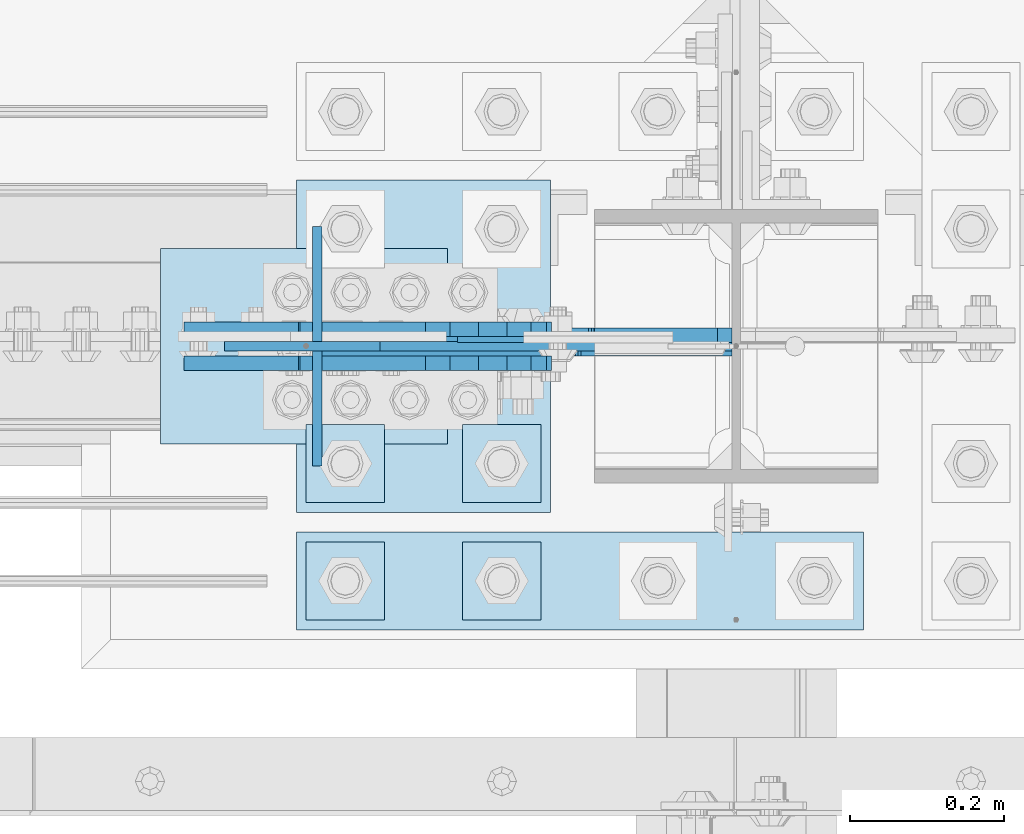
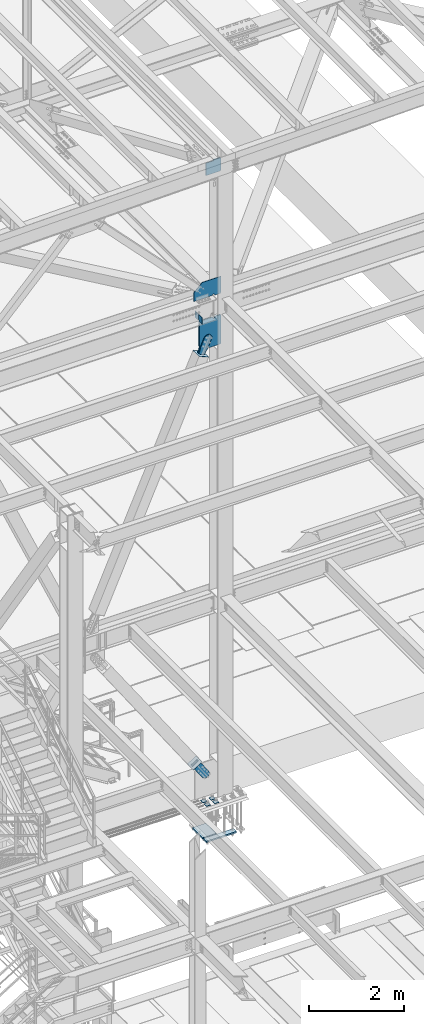
# One storey, part 3181 of 3843: 17 plates, 9 elements without a shape of their own.
"""IFC2X3 building model written with IfcOpenShell, lengths in millimetres."""

from ifc_helpers import new_model, si_unit, frame, origin_with_axes, place, context, subcontext, project, spatial, faceted_brep, material, type_object, element, aggregate, save


model = new_model("IFC2X3")

# Units and contexts
model_context = context("Model", 3, precision=1e-05, world=origin_with_axes())
body_context = subcontext(model_context, "Body", "Model", "MODEL_VIEW")
ifc_project = project(units=[si_unit("LENGTHUNIT", "METRE", prefix="MILLI"), si_unit("AREAUNIT", "SQUARE_METRE"), si_unit("VOLUMEUNIT", "CUBIC_METRE"), si_unit("MASSUNIT", "GRAM", prefix="KILO"), si_unit("TIMEUNIT", "SECOND"), si_unit("PLANEANGLEUNIT", "RADIAN"), si_unit("SOLIDANGLEUNIT", "STERADIAN"), si_unit("THERMODYNAMICTEMPERATUREUNIT", "DEGREE_CELSIUS"), si_unit("LUMINOUSINTENSITYUNIT", "LUMEN")], contexts=[model_context])

# Site, building, storey
site_placement = place(None, origin_with_axes())
site = spatial("IfcSite", under=ifc_project, at=site_placement, CompositionType="ELEMENT")
building_placement = place(site_placement, origin_with_axes())
building = spatial("IfcBuilding", under=site, at=building_placement, Name="Undefined", CompositionType="ELEMENT")
storey_placement = place(building_placement, origin_with_axes())
storey = spatial("IfcBuildingStorey", under=building, at=storey_placement, Name="Undefined", CompositionType="ELEMENT", Elevation=0.0)

# Assembly, plates
assembly_1_placement = place(storey_placement, origin_with_axes())
assembly_1 = element("IfcElementAssembly", 1, at=assembly_1_placement, inside=storey, Name="BEAM", AssemblyPlace="NOTDEFINED", PredefinedType="RIGID_FRAME")
ifc_material_1 = material(Name="STEEL/A572-50")
plate_type_1 = type_object("IfcPlateType", PredefinedType="NOTDEFINED")
plate_1_placement = place(assembly_1_placement, frame((62092.0351249223, 25609.55, 42110.025), z_axis=(0.0, 0.0, -1.0), x_axis=(0.0, -1.0, 0.0)))
plate_1 = element("IfcPlate", 2, at=plate_1_placement, type_object=plate_type_1, material=ifc_material_1, Name="PLATE", context=body_context, shape_type="Brep", body=[
    faceted_brep([(0.0, -6.3499999046162, 0.0), (0.0, -6.35000000000582, 131.762499999997), (0.0, 6.35000000000582, 131.762499999997), (7.27595761418343e-12, 6.3499999046162, 0.0), (31.75, -6.35000000000582, 163.512499999997), (31.75, 6.35000000000582, 163.512499999997), (149.224999999991, -6.35000000000582, 163.512499999997), (149.224999999991, 6.35000000000582, 163.512499999997), (149.224999999991, -6.35000000000582, 0.0), (149.224999999991, 6.35000000000582, 0.0)], [[[0, 1, 2, 3]], [[1, 4, 5, 2]], [[4, 6, 7, 5]], [[6, 8, 9, 7]], [[8, 0, 3, 9]], [[5, 7, 9, 3, 2]], [[8, 6, 4, 1, 0]]]),
])
plate_2_placement = place(assembly_1_placement, frame((62092.0351249223, 25771.475, 42110.025), z_axis=(0.0, 0.0, -1.0), x_axis=(0.0, -1.0, 0.0)))
plate_2 = element("IfcPlate", 3, at=plate_2_placement, type_object=plate_type_1, material=ifc_material_1, Name="PLATE", context=body_context, shape_type="Brep", body=[
    faceted_brep([(0.0, -6.3499999046162, 0.0), (0.0, -6.34999999999854, 163.512499999997), (0.0, 6.34999999999854, 163.512499999997), (7.27595761418343e-12, 6.3499999046162, 0.0), (117.474999999991, -6.34999999999854, 163.512499999997), (117.474999999991, 6.34999999999854, 163.512499999997), (149.224999999991, -6.34999999999854, 131.762499999997), (149.224999999991, 6.34999999999854, 131.762499999997), (149.224999999991, -6.35000000000582, 0.0), (149.224999999991, 6.35000000000582, 0.0)], [[[0, 1, 2, 3]], [[1, 4, 5, 2]], [[4, 6, 7, 5]], [[6, 8, 9, 7]], [[8, 0, 3, 9]], [[5, 7, 9, 3, 2]], [[8, 6, 4, 1, 0]]]),
])
aggregate(assembly_1, [plate_1, plate_2])

# Assembly, plate
assembly_2_placement = place(storey_placement, origin_with_axes())
assembly_2 = element("IfcElementAssembly", 4, at=assembly_2_placement, inside=storey, Name="COLUMN", AssemblyPlace="NOTDEFINED", PredefinedType="RIGID_FRAME")
plate_type_2 = type_object("IfcPlateType", PredefinedType="NOTDEFINED")
plate_3_placement = place(assembly_2_placement, frame((62098.3851249223, 25615.9, 42468.8), z_axis=(0.0, 0.0, -1.0), x_axis=(1.0, 0.0, 0.0)))
plate_3 = element("IfcPlate", 5, at=plate_3_placement, type_object=plate_type_2, material=ifc_material_1, Name="CB", context=body_context, shape_type="Brep", body=[
    faceted_brep([(513.296967251517, 12.7000000000007, 542.925000000003), (513.296967251517, -12.7000000000007, 542.925000000003), (379.153217251514, -12.7000000000007, 542.925000000003), (379.153217251514, 12.7000000000007, 542.925000000003), (379.153217251514, -12.7000000000007, 568.325000190736), (379.153217251514, 12.7000000000007, 568.325000190736), (378.186487328923, -12.7000000000007, 573.185079708783), (378.186487328923, 12.7000000000007, 573.185079708783), (375.433473428449, -12.7000000000007, 577.305256176936), (375.433473428449, 12.7000000000007, 577.305256176936), (371.313296960296, -12.7000000000007, 580.05827007741), (371.313296960296, 12.7000000000007, 580.05827007741), (366.453217442249, -12.7000000000007, 581.025000000001), (366.453217442249, 12.7000000000007, 581.025000000001), (341.128708774966, -12.7000000000007, 581.025000000001), (341.128708774966, 12.7000000000007, 581.025000000001), (336.26862925692, -12.7000000000007, 580.05827007741), (336.26862925692, 12.7000000000007, 580.05827007741), (332.148452788766, -12.7000000000007, 577.305256176936), (332.148452788766, 12.7000000000007, 577.305256176936), (329.395438888292, -12.7000000000007, 573.185079708783), (329.395438888292, 12.7000000000007, 573.185079708783), (328.428708965701, -12.7000000000007, 568.325000190736), (328.428708965701, 12.7000000000007, 568.325000190736), (328.428708965701, -12.7000000000007, 542.925000000003), (328.428708965701, 12.7000000000007, 542.925000000003), (0.0, -12.7000000000007, 542.925000000003), (0.0, 12.7000000000007, 542.925000000003), (0.0, -12.7000000000007, 1188.66468498625), (0.0, 12.7000000000007, 1188.66468498625), (248.782756516986, -12.7000000000007, 1298.2906209775), (248.782756516986, 12.7000000000007, 1298.2906209775), (514.090717632986, -12.7000000000007, 1298.2906209775), (514.090717632986, 12.7000000000007, 1298.2906209775), (532.45862507767, -12.7000000000007, 1279.92271353282), (532.45862507767, 12.7000000000007, 1279.92271353282), (532.45862507767, 12.7000000000007, 562.086657826156), (532.45862507767, -12.7000000000007, 562.086657826156)], [[[0, 1, 2, 3]], [[4, 5, 3, 2]], [[6, 7, 5, 4]], [[8, 9, 7, 6]], [[10, 11, 9, 8]], [[12, 13, 11, 10]], [[14, 15, 13, 12]], [[16, 17, 15, 14]], [[18, 19, 17, 16]], [[20, 21, 19, 18]], [[22, 23, 21, 20]], [[24, 25, 23, 22]], [[26, 27, 25, 24]], [[28, 29, 27, 26]], [[28, 30, 31, 29]], [[30, 32, 33, 31]], [[33, 32, 34, 35]], [[0, 3, 5, 7, 9, 11, 13, 15, 17, 19, 21, 23, 25, 27, 29, 31, 33, 35, 36]], [[1, 0, 36, 37]], [[32, 30, 28, 26, 24, 22, 20, 18, 16, 14, 12, 10, 8, 6, 4, 2, 1, 37, 34]], [[36, 35, 34, 37]]]),
])

# Assembly, plates
assembly_3_placement = place(storey_placement, origin_with_axes())
assembly_3 = element("IfcElementAssembly", 6, at=assembly_3_placement, inside=storey, Name="TEMPLATE", AssemblyPlace="NOTDEFINED", PredefinedType="RIGID_FRAME")
plate_type_3 = type_object("IfcPlateType", PredefinedType="NOTDEFINED")
plate_4_placement = place(assembly_3_placement, frame((62179.2, 25361.9, 29686.25), z_axis=(-1.0, 0.0, 0.0), x_axis=(0.0, -1.0, 0.0)))
plate_4 = element("IfcPlate", 7, at=plate_4_placement, type_object=plate_type_3, material=ifc_material_1, Name="Washer Plate", context=body_context, shape_type="Brep", body=[
    faceted_brep([(0.0, -6.3499999046162, 0.0), (-1.67347025126219e-10, -6.35000000000582, 101.600000000151), (-1.67347025126219e-10, 6.35000000000582, 101.600000000151), (7.27595761418343e-12, 6.3499999046162, 0.0), (101.599998474121, -6.34999999999854, 101.599998474121), (101.599998474121, 6.34999999999854, 101.599998474121), (101.6, -6.34999999999854, 0.0), (101.6, 6.34999999999854, 0.0)], [[[0, 1, 2, 3]], [[1, 4, 5, 2]], [[4, 6, 7, 5]], [[6, 0, 3, 7]], [[5, 7, 3, 2]], [[6, 4, 1, 0]]]),
])
plate_5_placement = place(assembly_3_placement, frame((62382.4, 25361.9, 29686.25), z_axis=(-1.0, 0.0, 0.0), x_axis=(0.0, -1.0, 0.0)))
plate_5 = element("IfcPlate", 8, at=plate_5_placement, type_object=plate_type_3, material=ifc_material_1, Name="Washer Plate", context=body_context, shape_type="Brep", body=[
    faceted_brep([(0.0, -6.3499999046162, 0.0), (-1.67347025126219e-10, -6.35000000000582, 101.600000000151), (-1.67347025126219e-10, 6.35000000000582, 101.600000000151), (7.27595761418343e-12, 6.3499999046162, 0.0), (101.599998474121, -6.34999999999854, 101.599998474121), (101.599998474121, 6.34999999999854, 101.599998474121), (101.6, -6.34999999999854, 0.0), (101.6, 6.34999999999854, 0.0)], [[[0, 1, 2, 3]], [[1, 4, 5, 2]], [[4, 6, 7, 5]], [[6, 0, 3, 7]], [[5, 7, 3, 2]], [[6, 4, 1, 0]]]),
])
plate_6_placement = place(assembly_3_placement, frame((62179.2, 25514.3, 29686.25), z_axis=(-1.0, 0.0, 0.0), x_axis=(0.0, -1.0, 0.0)))
plate_6 = element("IfcPlate", 9, at=plate_6_placement, type_object=plate_type_3, material=ifc_material_1, Name="Washer Plate", context=body_context, shape_type="Brep", body=[
    faceted_brep([(0.0, -6.3499999046162, 0.0), (-1.67347025126219e-10, -6.35000000000582, 101.600000000151), (-1.67347025126219e-10, 6.35000000000582, 101.600000000151), (7.27595761418343e-12, 6.3499999046162, 0.0), (101.599998474121, -6.34999999999854, 101.599998474121), (101.599998474121, 6.34999999999854, 101.599998474121), (101.6, -6.34999999999854, 0.0), (101.6, 6.34999999999854, 0.0)], [[[0, 1, 2, 3]], [[1, 4, 5, 2]], [[4, 6, 7, 5]], [[6, 0, 3, 7]], [[5, 7, 3, 2]], [[6, 4, 1, 0]]]),
])
plate_7_placement = place(assembly_3_placement, frame((62382.4, 25514.3, 29686.25), z_axis=(-1.0, 0.0, 0.0), x_axis=(0.0, -1.0, 0.0)))
plate_7 = element("IfcPlate", 10, at=plate_7_placement, type_object=plate_type_3, material=ifc_material_1, Name="Washer Plate", context=body_context, shape_type="Brep", body=[
    faceted_brep([(0.0, -6.3499999046162, 0.0), (-1.67347025126219e-10, -6.35000000000582, 101.600000000151), (-1.67347025126219e-10, 6.35000000000582, 101.600000000151), (7.27595761418343e-12, 6.3499999046162, 0.0), (101.599998474121, -6.34999999999854, 101.599998474121), (101.599998474121, 6.34999999999854, 101.599998474121), (101.6, -6.34999999999854, 0.0), (101.6, 6.34999999999854, 0.0)], [[[0, 1, 2, 3]], [[1, 4, 5, 2]], [[4, 6, 7, 5]], [[6, 0, 3, 7]], [[5, 7, 3, 2]], [[6, 4, 1, 0]]]),
])

# Assembly, plate
assembly_4_placement = place(storey_placement, origin_with_axes())
assembly_4 = element("IfcElementAssembly", 11, at=assembly_4_placement, inside=storey, AssemblyPlace="NOTDEFINED", PredefinedType="RIGID_FRAME")
ifc_material_2 = material(Name="STEEL/A36")
plate_type_4 = type_object("IfcPlateType", PredefinedType="NOTDEFINED")
plate_8_placement = place(assembly_4_placement, frame((62067.4857896757, 25638.125, 30671.6692954389), z_axis=(-0.825644641353306, 0.0, -0.564190505241423), x_axis=(0.564190505241422, 0.0, -0.825644641353306)))
plate_8 = element("IfcPlate", 12, at=plate_8_placement, type_object=plate_type_4, material=ifc_material_2, context=body_context, shape_type="Brep", body=[
    faceted_brep([(0.0, -9.52500000000146, 0.0), (7.37782102078199e-09, -9.52499999999418, 179.651701450231), (7.37782102078199e-09, 9.52499999999418, 179.651701450231), (0.0, 9.52500000000146, 0.0), (69.8500000062704, -9.52499999999418, 179.651701450392), (69.8500000062704, 9.52499999999418, 179.651701450392), (171.449999998309, -9.52499999999418, 186.663350727089), (171.449999998309, 9.52499999999418, 186.663350727089), (434.579297655291, -9.52499999999418, 186.663350728457), (434.579297655291, 9.52499999999418, 186.663350728457), (471.637405120986, -9.52499999999418, 179.292034842016), (471.637405120986, 9.52499999999418, 179.292034842016), (503.05375165752, -9.52499999999418, 158.300303204887), (503.05375165752, 9.52499999999418, 158.300303204887), (524.045483294532, -9.52499999999418, 126.883956668345), (524.045483294532, 9.52499999999418, 126.883956668345), (531.416799180792, -9.52499999999418, 89.8258522538526), (531.416799180792, 9.52499999999418, 89.8258522538526), (524.045483293885, -9.52499999999418, 52.7677447886235), (524.045483293885, 9.52499999999418, 52.7677447886235), (503.053751656611, -9.52499999999418, 21.3513982523873), (503.053751656611, 9.52499999999418, 21.3513982523873), (471.637405120178, -9.52499999999418, 0.359666615346214), (471.637405120178, 9.52499999999418, 0.359666615346214), (434.579299181831, -9.52499999999418, -7.01164927131322), (434.579299181831, 9.52499999999418, -7.01164927131322), (171.449999996272, -9.52499999999418, -7.01164927269565), (171.449999996272, 9.52499999999418, -7.01164927269565), (69.8499999979995, -9.52499999999418, -4.00177668780088e-10), (69.8499999979995, 9.52499999999418, -4.00177668780088e-10)], [[[0, 1, 2, 3]], [[1, 4, 5, 2]], [[4, 6, 7, 5]], [[6, 8, 9, 7]], [[8, 10, 11, 9]], [[10, 12, 13, 11]], [[12, 14, 15, 13]], [[14, 16, 17, 15]], [[16, 18, 19, 17]], [[18, 20, 21, 19]], [[20, 22, 23, 21]], [[22, 24, 25, 23]], [[24, 26, 27, 25]], [[26, 28, 29, 27]], [[28, 0, 3, 29]], [[5, 7, 9, 11, 13, 15, 17, 19, 21, 23, 25, 27, 29, 3, 2]], [[28, 26, 24, 22, 20, 18, 16, 14, 12, 10, 8, 6, 4, 1, 0]]]),
])
aggregate(assembly_4, [plate_8])

assembly_5_placement = place(storey_placement, origin_with_axes())
assembly_5 = element("IfcElementAssembly", 13, at=assembly_5_placement, inside=storey, AssemblyPlace="NOTDEFINED", PredefinedType="RIGID_FRAME")
plate_9_placement = place(assembly_5_placement, frame((62067.4857896757, 25593.675, 30671.6692954389), z_axis=(-0.825644641353306, 0.0, -0.564190505241423), x_axis=(0.564190505241422, 0.0, -0.825644641353306)))
plate_9 = element("IfcPlate", 14, at=plate_9_placement, type_object=plate_type_4, material=ifc_material_2, context=body_context, shape_type="Brep", body=[
    faceted_brep([(0.0, -9.52500000000146, 0.0), (7.37782102078199e-09, -9.52499999999418, 179.651701450231), (7.37782102078199e-09, 9.52499999999418, 179.651701450231), (0.0, 9.52500000000146, 0.0), (69.8500000062704, -9.52499999999418, 179.651701450392), (69.8500000062704, 9.52499999999418, 179.651701450392), (171.449999998309, -9.52499999999418, 186.663350727089), (171.449999998309, 9.52499999999418, 186.663350727089), (434.579297655291, -9.52499999999418, 186.663350728457), (434.579297655291, 9.52499999999418, 186.663350728457), (471.637405120986, -9.52499999999418, 179.292034842016), (471.637405120986, 9.52499999999418, 179.292034842016), (503.05375165752, -9.52499999999418, 158.300303204887), (503.05375165752, 9.52499999999418, 158.300303204887), (524.045483294532, -9.52499999999418, 126.883956668345), (524.045483294532, 9.52499999999418, 126.883956668345), (531.416799180792, -9.52499999999418, 89.8258522538526), (531.416799180792, 9.52499999999418, 89.8258522538526), (524.045483293885, -9.52499999999418, 52.7677447886235), (524.045483293885, 9.52499999999418, 52.7677447886235), (503.053751656611, -9.52499999999418, 21.3513982523873), (503.053751656611, 9.52499999999418, 21.3513982523873), (471.637405120178, -9.52499999999418, 0.359666615346214), (471.637405120178, 9.52499999999418, 0.359666615346214), (434.579299181831, -9.52499999999418, -7.01164927131322), (434.579299181831, 9.52499999999418, -7.01164927131322), (171.449999996272, -9.52499999999418, -7.01164927269565), (171.449999996272, 9.52499999999418, -7.01164927269565), (69.8499999979995, -9.52499999999418, -4.00177668780088e-10), (69.8499999979995, 9.52499999999418, -4.00177668780088e-10)], [[[0, 1, 2, 3]], [[1, 4, 5, 2]], [[4, 6, 7, 5]], [[6, 8, 9, 7]], [[8, 10, 11, 9]], [[10, 12, 13, 11]], [[12, 14, 15, 13]], [[14, 16, 17, 15]], [[16, 18, 19, 17]], [[18, 20, 21, 19]], [[20, 22, 23, 21]], [[22, 24, 25, 23]], [[24, 26, 27, 25]], [[26, 28, 29, 27]], [[28, 0, 3, 29]], [[5, 7, 9, 11, 13, 15, 17, 19, 21, 23, 25, 27, 29, 3, 2]], [[28, 26, 24, 22, 20, 18, 16, 14, 12, 10, 8, 6, 4, 1, 0]]]),
])
aggregate(assembly_5, [plate_9])

assembly_6_placement = place(storey_placement, origin_with_axes())
assembly_6 = element("IfcElementAssembly", 15, at=assembly_6_placement, inside=storey, AssemblyPlace="NOTDEFINED", PredefinedType="RIGID_FRAME")
plate_10_placement = place(assembly_6_placement, frame((62214.6246248683, 25638.125, 41041.6616640646), z_axis=(-0.91516437406824, 0.0, 0.403080846030032), x_axis=(0.403080846030053, 0.0, 0.915164374068231)))
plate_10 = element("IfcPlate", 16, at=plate_10_placement, type_object=plate_type_4, material=ifc_material_2, context=body_context, shape_type="Brep", body=[
    faceted_brep([(0.0, -9.52500000000146, 0.0), (1.71894498635083e-09, -9.52499999999418, 158.39421297863), (1.71894498635083e-09, 9.52499999999418, 158.39421297863), (0.0, 9.52500000000146, 0.0), (69.8500000010408, -9.52499999999418, 158.394212979103), (69.8500000010408, 9.52499999999418, 158.394212979103), (171.450000002631, -9.52499999999418, 176.034606488582), (171.450000002631, 9.52499999999418, 176.034606488582), (390.129297671807, -9.52499999999418, 176.034606487716), (390.129297671807, 9.52499999999418, 176.034606487716), (427.187405137312, -9.52499999999418, 168.663290600991), (427.187405137312, 9.52499999999418, 168.663290600991), (458.60375167372, -9.52499999999418, 147.671558963724), (458.60375167372, 9.52499999999418, 147.671558963724), (479.59548331075, -9.52499999999418, 116.255212427161), (479.59548331075, 9.52499999999418, 116.255212427161), (486.966799197198, -9.52499999999418, 79.1971080138683), (486.966799197198, 9.52499999999418, 79.1971080138683), (479.595483310488, -9.52499999999418, 42.1390005483336), (479.595483310488, 9.52499999999418, 42.1390005483336), (458.603751673207, -9.52499999999418, 10.7226540119082), (458.603751673207, 9.52499999999418, 10.7226540119082), (427.18740513661, -9.52499999999418, -10.2690776251402), (427.18740513661, 9.52499999999418, -10.2690776251402), (390.129299195723, -9.52499999999418, -17.6403935115741), (390.129299195723, 9.52499999999418, -17.6403935115741), (171.450000001962, -9.52499999999418, -17.6403935107155), (171.450000001962, 9.52499999999418, -17.6403935107155), (69.8499999979995, -9.52499999999418, -4.00177668780088e-10), (69.8499999979995, 9.52499999999418, -4.00177668780088e-10)], [[[0, 1, 2, 3]], [[1, 4, 5, 2]], [[4, 6, 7, 5]], [[6, 8, 9, 7]], [[8, 10, 11, 9]], [[10, 12, 13, 11]], [[12, 14, 15, 13]], [[14, 16, 17, 15]], [[16, 18, 19, 17]], [[18, 20, 21, 19]], [[20, 22, 23, 21]], [[22, 24, 25, 23]], [[24, 26, 27, 25]], [[26, 28, 29, 27]], [[28, 0, 3, 29]], [[5, 7, 9, 11, 13, 15, 17, 19, 21, 23, 25, 27, 29, 3, 2]], [[28, 26, 24, 22, 20, 18, 16, 14, 12, 10, 8, 6, 4, 1, 0]]]),
])
aggregate(assembly_6, [plate_10])

assembly_7_placement = place(storey_placement, origin_with_axes())
assembly_7 = element("IfcElementAssembly", 17, at=assembly_7_placement, inside=storey, AssemblyPlace="NOTDEFINED", PredefinedType="RIGID_FRAME")
plate_11_placement = place(assembly_7_placement, frame((62214.6246248683, 25593.675, 41041.6616640646), z_axis=(-0.91516437406824, 0.0, 0.403080846030032), x_axis=(0.403080846030053, 0.0, 0.915164374068231)))
plate_11 = element("IfcPlate", 18, at=plate_11_placement, type_object=plate_type_4, material=ifc_material_2, context=body_context, shape_type="Brep", body=[
    faceted_brep([(0.0, -9.52500000000146, 0.0), (1.71894498635083e-09, -9.52499999999418, 158.39421297863), (1.71894498635083e-09, 9.52499999999418, 158.39421297863), (0.0, 9.52500000000146, 0.0), (69.8500000010408, -9.52499999999418, 158.394212979103), (69.8500000010408, 9.52499999999418, 158.394212979103), (171.450000002631, -9.52499999999418, 176.034606488582), (171.450000002631, 9.52499999999418, 176.034606488582), (390.129297671807, -9.52499999999418, 176.034606487716), (390.129297671807, 9.52499999999418, 176.034606487716), (427.187405137312, -9.52499999999418, 168.663290600991), (427.187405137312, 9.52499999999418, 168.663290600991), (458.60375167372, -9.52499999999418, 147.671558963724), (458.60375167372, 9.52499999999418, 147.671558963724), (479.59548331075, -9.52499999999418, 116.255212427161), (479.59548331075, 9.52499999999418, 116.255212427161), (486.966799197198, -9.52499999999418, 79.1971080138683), (486.966799197198, 9.52499999999418, 79.1971080138683), (479.595483310488, -9.52499999999418, 42.1390005483336), (479.595483310488, 9.52499999999418, 42.1390005483336), (458.603751673207, -9.52499999999418, 10.7226540119082), (458.603751673207, 9.52499999999418, 10.7226540119082), (427.18740513661, -9.52499999999418, -10.2690776251402), (427.18740513661, 9.52499999999418, -10.2690776251402), (390.129299195723, -9.52499999999418, -17.6403935115741), (390.129299195723, 9.52499999999418, -17.6403935115741), (171.450000001962, -9.52499999999418, -17.6403935107155), (171.450000001962, 9.52499999999418, -17.6403935107155), (69.8499999979995, -9.52499999999418, -4.00177668780088e-10), (69.8499999979995, 9.52499999999418, -4.00177668780088e-10)], [[[0, 1, 2, 3]], [[1, 4, 5, 2]], [[4, 6, 7, 5]], [[6, 8, 9, 7]], [[8, 10, 11, 9]], [[10, 12, 13, 11]], [[12, 14, 15, 13]], [[14, 16, 17, 15]], [[16, 18, 19, 17]], [[18, 20, 21, 19]], [[20, 22, 23, 21]], [[22, 24, 25, 23]], [[24, 26, 27, 25]], [[26, 28, 29, 27]], [[28, 0, 3, 29]], [[5, 7, 9, 11, 13, 15, 17, 19, 21, 23, 25, 27, 29, 3, 2]], [[28, 26, 24, 22, 20, 18, 16, 14, 12, 10, 8, 6, 4, 1, 0]]]),
])
aggregate(assembly_7, [plate_11])

assembly_8_placement = place(storey_placement, origin_with_axes())
assembly_8 = element("IfcElementAssembly", 19, at=assembly_8_placement, inside=storey, Name="Plate", AssemblyPlace="NOTDEFINED", PredefinedType="RIGID_FRAME")
plate_type_5 = type_object("IfcPlateType", PredefinedType="NOTDEFINED")
plate_12_placement = place(assembly_8_placement, frame((61890.2559929795, 25742.9, 30546.7167875752), z_axis=(0.825644641353306, 0.0, 0.564190505241423), x_axis=(0.0, -1.0, 0.0)))
plate_12 = element("IfcPlate", 20, at=plate_12_placement, type_object=plate_type_5, material=ifc_material_2, Name="Plate", context=body_context, shape_type="Brep", body=[
    faceted_brep([(0.0, -3.17499999999927, 0.0), (0.0, -3.17499999965185, 254.000000005151), (0.0, 3.17500000035216, 254.000000005166), (0.0, 3.17499999999927, 0.0), (254.0, -3.17499999965185, 254.000000005151), (254.0, 3.17500000035216, 254.000000005166), (254.0, -3.17500000000291, 0.0), (254.0, 3.17499999999927, 1.45519152283669e-11)], [[[0, 1, 2, 3]], [[1, 4, 5, 2]], [[4, 6, 7, 5]], [[6, 0, 3, 7]], [[5, 7, 3, 2]], [[6, 4, 1, 0]]]),
])
aggregate(assembly_8, [plate_12])

assembly_9_placement = place(storey_placement, origin_with_axes())
assembly_9 = element("IfcElementAssembly", 21, at=assembly_9_placement, inside=storey, Name="Plate", AssemblyPlace="NOTDEFINED", PredefinedType="RIGID_FRAME")
plate_13_placement = place(assembly_9_placement, frame((62259.651911486, 25488.9, 41025.2988802587), z_axis=(-0.91516437406824, 0.0, 0.403080846030032), x_axis=(0.0, 1.0, 0.0)))
plate_13 = element("IfcPlate", 22, at=plate_13_placement, type_object=plate_type_5, material=ifc_material_2, Name="Plate", context=body_context, shape_type="Brep", body=[
    faceted_brep([(0.0, -3.17499999999927, 0.0), (0.0, -3.17499999965185, 254.000000005151), (0.0, 3.17500000035216, 254.000000005166), (0.0, 3.17499999999927, 0.0), (254.0, -3.17499999965185, 254.000000005151), (254.0, 3.17500000035216, 254.000000005166), (254.0, -3.17500000000291, 0.0), (254.0, 3.17499999999927, 1.45519152283669e-11)], [[[0, 1, 2, 3]], [[1, 4, 5, 2]], [[4, 6, 7, 5]], [[6, 0, 3, 7]], [[5, 7, 3, 2]], [[6, 4, 1, 0]]]),
])
aggregate(assembly_9, [plate_13])

# Plate
plate_type_6 = type_object("IfcPlateType", PredefinedType="NOTDEFINED")
plate_14_placement = place(assembly_2_placement, frame((62630.8437500057, 25615.9000004153, 42468.8000000061), z_axis=(0.0, 0.0, 1.0), x_axis=(-1.0, 0.0, 0.0)))
plate_14 = element("IfcPlate", 23, at=plate_14_placement, type_object=plate_type_6, material=ifc_material_1, Name="PLATE", context=body_context, shape_type="Brep", body=[
    faceted_brep([(19.0499992370605, -6.34999999999854, 0.0), (0.0, -6.34999999999854, 19.0499992370605), (0.0, 6.34999999999854, 19.0499992370605), (19.0499992370605, 6.34999999999854, 0.0), (0.0, -6.35000000000582, 431.157586934591), (457.543662687145, -6.35000000000582, 431.157586934591), (457.543662687145, 6.35000000000582, 431.157586934591), (0.0, 6.35000000000582, 431.157586934591), (659.125550514334, -6.35000000000582, 237.691562785578), (659.125550514334, 6.35000000000582, 237.691562785578), (659.125550514334, -6.35000000000582, 12.6999999938635), (659.125550514334, 6.35000000000582, 12.6999999938635), (203.993749999323, -6.35000000000582, 12.6999999987602), (203.993749999323, 6.35000000000582, 12.6999999987602), (203.993749999323, -6.35000000000582, 25.4000001894965), (203.993749999323, 6.35000000000582, 25.4000001894965), (203.027020076735, -6.35000000000582, 30.2600797075429), (203.027020076735, 6.35000000000582, 30.2600797075429), (200.274006176258, -6.35000000000582, 34.3802561756966), (200.274006176258, 6.35000000000582, 34.3802561756966), (196.153829708104, -6.35000000000582, 37.1332700761704), (196.153829708104, 6.35000000000582, 37.1332700761704), (191.293750190058, -6.35000000000582, 38.0999999987616), (191.293750190058, 6.35000000000582, 38.0999999987616), (165.893749808589, -6.35000000000582, 38.0999999987616), (165.893749808589, 6.35000000000582, 38.0999999987616), (161.033670290542, -6.35000000000582, 37.1332700761704), (161.033670290542, 6.35000000000582, 37.1332700761704), (156.913493822389, -6.35000000000582, 34.3802561756966), (156.913493822389, 6.35000000000582, 34.3802561756966), (154.160479921911, -6.35000000000582, 30.2600797075429), (154.160479921911, 6.35000000000582, 30.2600797075429), (153.193749999324, -6.35000000000582, 25.4000001894965), (153.193749999324, 6.35000000000582, 25.4000001894965), (153.193749999324, -6.35000000000582, -1.04046193882823e-09), (153.193749999324, 6.35000000000582, 0.0)], [[[0, 1, 2, 3]], [[4, 5, 6, 7]], [[5, 8, 9, 6]], [[9, 8, 10, 11]], [[10, 12, 13, 11]], [[14, 15, 13, 12]], [[16, 17, 15, 14]], [[18, 19, 17, 16]], [[20, 21, 19, 18]], [[22, 23, 21, 20]], [[24, 25, 23, 22]], [[26, 27, 25, 24]], [[28, 29, 27, 26]], [[30, 31, 29, 28]], [[32, 33, 31, 30]], [[34, 35, 33, 32]], [[0, 3, 35, 34]], [[7, 6, 9, 11, 13, 15, 17, 19, 21, 23, 25, 27, 29, 31, 33, 35, 3, 2]], [[4, 7, 2, 1]], [[34, 32, 30, 28, 26, 24, 22, 20, 18, 16, 14, 12, 10, 8, 5, 4, 1, 0]]]),
])

plate_type_7 = type_object("IfcPlateType", PredefinedType="NOTDEFINED")
plate_15_placement = place(assembly_2_placement, frame((62630.84375, 25630.1875003815, 45620.9852003891), z_axis=(-0.707106781186548, 0.0, 0.707106781186548), x_axis=(-0.707106781186548, 0.0, -0.707106781186548)))
plate_15 = element("IfcPlate", 24, at=plate_15_placement, type_object=plate_type_7, material=ifc_material_1, Name="PLATE", context=body_context, shape_type="Brep", body=[
    faceted_brep([(0.0, -9.52500000000146, 0.0), (-217.83702560261, -9.52500000000146, 217.837025602606), (-217.83702560261, 9.52500000000146, 217.837025602606), (0.0, 9.52500000000146, 0.0), (-217.837025602319, -9.52500000000146, 244.777793965968), (-217.837025602319, 9.52500000000146, 244.777793965968), (-105.02255807961, -9.52500000000146, 357.592261488677), (-105.02255807961, 9.52500000000146, 357.592261488677), (-94.254791630985, -9.52500000000146, 346.824495040062), (-94.254791630985, 9.52500000000146, 346.824495040062), (-90.1346151628532, -9.52500000000146, 344.071481139596), (-90.1346151628532, 9.52500000000146, 344.071481139596), (-85.2745356447995, -9.52500000000146, 343.104751217026), (-85.2745356447995, 9.52500000000146, 343.104751217026), (-80.4144561267167, -9.52500000000146, 344.07148113965), (-80.4144561267167, 9.52500000000146, 344.07148113965), (-76.2942796585558, -9.52500000000146, 346.824495040149), (-76.2942796585558, 9.52500000000146, 346.824495040149), (40.4490500521206, -9.52500000000146, 463.567824750826), (40.4490500521206, 9.52500000000146, 463.567824750826), (264.955453077768, -9.52500000000146, 239.061421725179), (264.955453077768, 9.52500000000146, 239.061421725179), (26.9407683632344, -9.52499999999964, 2.03726813197136e-10), (26.9407683632344, 9.52499999999964, 2.03726813197136e-10)], [[[0, 1, 2, 3]], [[1, 4, 5, 2]], [[4, 6, 7, 5]], [[6, 8, 9, 7]], [[8, 10, 11, 9]], [[10, 12, 13, 11]], [[12, 14, 15, 13]], [[14, 16, 17, 15]], [[16, 18, 19, 17]], [[18, 20, 21, 19]], [[20, 22, 23, 21]], [[22, 0, 3, 23]], [[5, 7, 9, 11, 13, 15, 17, 19, 21, 23, 3, 2]], [[22, 20, 18, 16, 14, 12, 10, 8, 6, 4, 1, 0]]]),
])

aggregate(assembly_2, [plate_3, plate_14, plate_15])

plate_type_8 = type_object("IfcPlateType", PredefinedType="NOTDEFINED")
plate_16_placement = place(assembly_3_placement, frame((62801.5, 25374.6, 28784.55), z_axis=(-1.0, 0.0, 0.0), x_axis=(0.0, -1.0, 0.0)))
plate_16 = element("IfcPlate", 25, at=plate_16_placement, type_object=plate_type_8, material=ifc_material_1, Name="PLATE", context=body_context, shape_type="Brep", body=[
    faceted_brep([(0.0, -19.0500000000029, 0.0), (0.0, -19.0499999999993, 736.600036621094), (0.0, 19.0499999999993, 736.600036621094), (0.0, 19.0500000000029, 0.0), (127.0, -19.0499999999993, 736.600036621094), (127.0, 19.0499999999993, 736.600036621094), (127.0, -19.0499999999993, 0.0), (127.0, 19.0499999999993, 0.0)], [[[0, 1, 2, 3]], [[1, 4, 5, 2]], [[4, 6, 7, 5]], [[6, 0, 3, 7]], [[5, 7, 3, 2]], [[6, 4, 1, 0]]]),
])

plate_type_9 = type_object("IfcPlateType", PredefinedType="NOTDEFINED")
plate_17_placement = place(assembly_3_placement, frame((62395.1, 25831.8, 28784.55), z_axis=(-1.0, 0.0, 0.0), x_axis=(0.0, -1.0, 0.0)))
plate_17 = element("IfcPlate", 26, at=plate_17_placement, type_object=plate_type_9, material=ifc_material_1, Name="PLATE", context=body_context, shape_type="Brep", body=[
    faceted_brep([(0.0, -19.0500000000029, 0.0), (0.0, -19.0499999999993, 330.200012207031), (0.0, 19.0499999999993, 330.200012207031), (0.0, 19.0500000000029, 0.0), (431.799957275391, -19.0499999999993, 330.200012207031), (431.799957275391, 19.0499999999993, 330.200012207031), (431.799957275391, -19.0499999999993, 0.0), (431.799957275391, 19.0499999999993, 0.0)], [[[0, 1, 2, 3]], [[1, 4, 5, 2]], [[4, 6, 7, 5]], [[6, 0, 3, 7]], [[5, 7, 3, 2]], [[6, 4, 1, 0]]]),
])

aggregate(assembly_3, [plate_4, plate_5, plate_6, plate_7, plate_17, plate_16])

save(model, "model.ifc")
